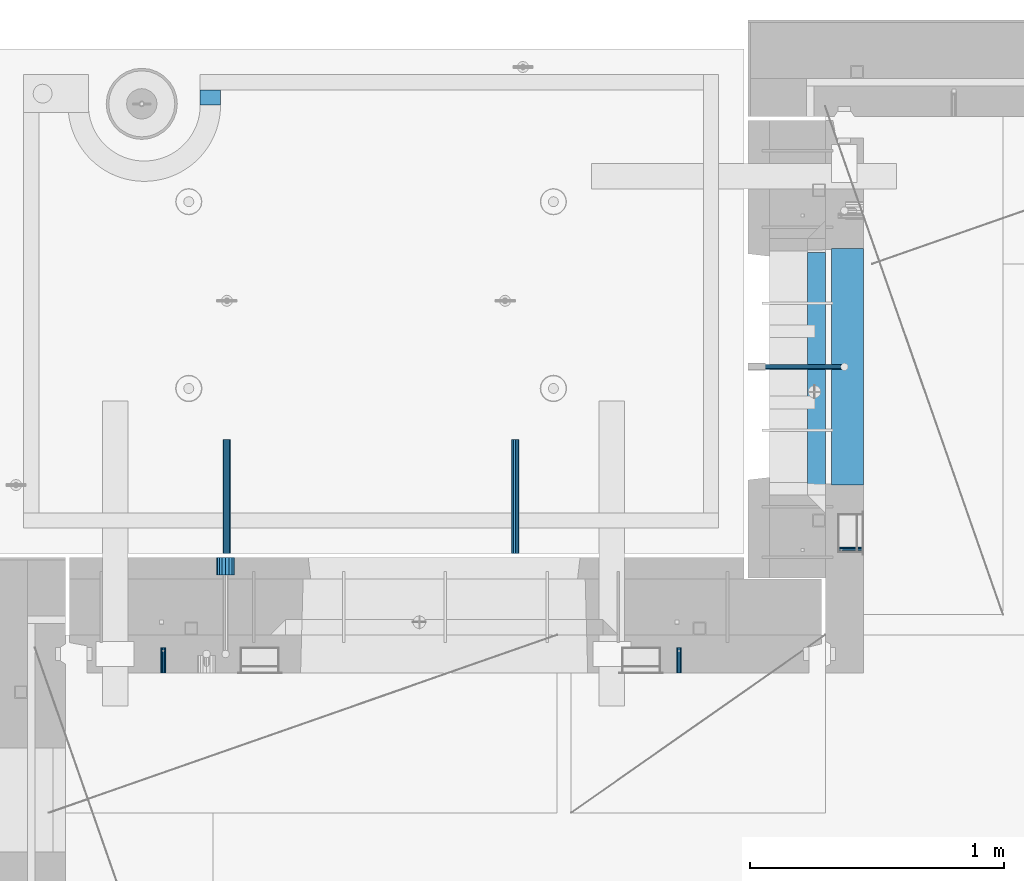
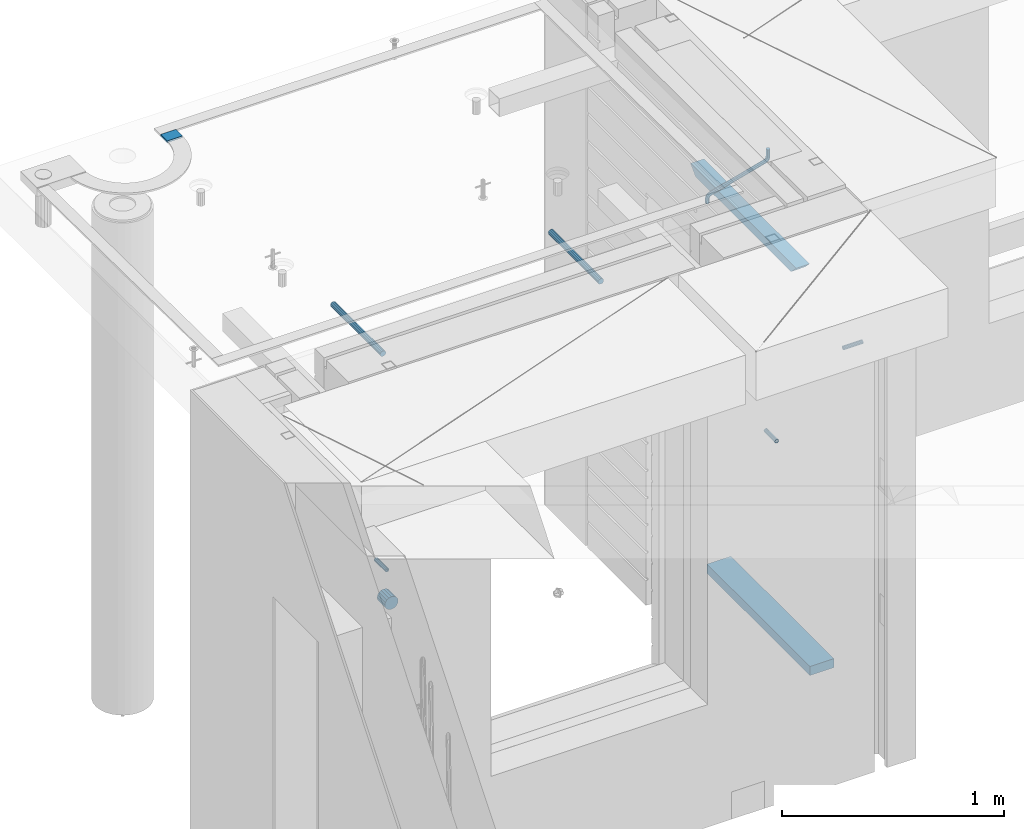
# One storey, part 152 of 341: 10 beams, 8 elements without a shape of their own.
"""IFC2X3 building model written with IfcOpenShell, lengths in millimetres."""

import ifcopenshell
import ifcopenshell.guid

model = None  # the IFC model being written
_history = None  # IfcOwnerHistory: only IFC2X3 demands one
_inside = {}  # id of a spatial element -> (the spatial element, [elements in it])
_under = {}  # id of a project, library or spatial element -> (it, [spatial elements below it])
_declared = {}  # id of a project -> (the project, [libraries it declares])
_typed = {}  # id of a type object -> (the type object, [elements of that type])
_made_of = {}  # id of a material, layer set ... -> (it, [elements and type objects made of it])


def new_model(schema):
    """Start an empty IFC model of exactly this schema.

    Asked for "IFC4X3", IfcOpenShell would pick the latest addendum, in which some entities
    have other attributes; the version numbers below select the first issue.
    IFC2X3 requires an IfcOwnerHistory on every rooted entity: one is made here for all.
    """
    global model, _history
    if schema == "IFC4X3":
        model = ifcopenshell.file(schema_version=(4, 3, 0, 0))
    else:
        model = ifcopenshell.file(schema=schema)
    _inside.clear()
    _under.clear()
    _declared.clear()
    _typed.clear()
    _made_of.clear()
    _history = None
    if model.schema == "IFC2X3":
        org = make("IfcOrganization", Name="unknown")
        user = make(
            "IfcPersonAndOrganization",
            ThePerson=make("IfcPerson", FamilyName="unknown"),
            TheOrganization=org,
        )
        app = make(
            "IfcApplication",
            ApplicationDeveloper=org,
            Version="unknown",
            ApplicationFullName="unknown",
            ApplicationIdentifier="unknown",
        )
        _history = make(
            "IfcOwnerHistory",
            OwningUser=user,
            OwningApplication=app,
            ChangeAction="ADDED",
            CreationDate=0,
        )
    return model


def make(cls, **values):
    """One entity of the class cls with the attributes given. An attribute that is None is left unset."""
    return model.create_entity(
        cls, **{name: value for name, value in values.items() if value is not None}
    )


def rooted(cls, **values):
    """An entity with a GlobalId (a new one), such as an element, a storey or a relation."""
    return make(cls, GlobalId=ifcopenshell.guid.new(), OwnerHistory=_history, **values)


def si_unit(unit_type, name, prefix=None):
    """IfcSIUnit, for example si_unit("LENGTHUNIT", "METRE", prefix="MILLI")."""
    return make("IfcSIUnit", UnitType=unit_type, Prefix=prefix, Name=name)


def assignment(units):
    """IfcUnitAssignment: the units of a project."""
    return None if units is None else make("IfcUnitAssignment", Units=units)


def point(xyz):
    """IfcCartesianPoint."""
    return None if xyz is None else make("IfcCartesianPoint", Coordinates=xyz)


def direction(xyz):
    """IfcDirection."""
    return None if xyz is None else make("IfcDirection", DirectionRatios=xyz)


def frame(location, z_axis=None, x_axis=None):
    """IfcAxis2Placement3D, a coordinate frame: its origin and axes. An axis left out is left unset."""
    return make(
        "IfcAxis2Placement3D",
        Location=point(location),
        Axis=direction(z_axis),
        RefDirection=direction(x_axis),
    )


def origin_with_axes():
    """The frame at (0, 0, 0) with the z axis (0, 0, 1) and the x axis (1, 0, 0) written out."""
    return frame((0.0, 0.0, 0.0), z_axis=(0.0, 0.0, 1.0), x_axis=(1.0, 0.0, 0.0))


def place(relative_to, where):
    """IfcLocalPlacement: puts the frame where relative to a parent placement (None: the world)."""
    return make(
        "IfcLocalPlacement", PlacementRelTo=relative_to, RelativePlacement=where
    )


def context(
    kind, dimensions, precision=None, world=None, true_north=None, identifier=None
):
    """IfcGeometricRepresentationContext, for example the 3D "Model" context."""
    return make(
        "IfcGeometricRepresentationContext",
        ContextIdentifier=identifier,
        ContextType=kind,
        CoordinateSpaceDimension=dimensions,
        Precision=precision,
        WorldCoordinateSystem=world,
        TrueNorth=true_north,
    )


def subcontext(parent, identifier, kind, view, scale=None):
    """IfcGeometricRepresentationSubContext, for example "Body" below "Model"."""
    return make(
        "IfcGeometricRepresentationSubContext",
        ContextIdentifier=identifier,
        ContextType=kind,
        ParentContext=parent,
        TargetScale=scale,
        TargetView=view,
    )


def project(units=None, contexts=None):
    """IfcProject with its units and contexts."""
    return rooted(
        "IfcProject",
        Name="project",
        RepresentationContexts=contexts,
        UnitsInContext=assignment(units),
    )


def spatial(cls, under=None, at=None, **own):
    """A site, building, storey or space (cls), placed at a placement, below another one or the project."""
    s = rooted(cls, ObjectPlacement=at, **own)
    if under is not None:
        _under.setdefault(under.id(), (under, []))[1].append(s)
    return s


def faces_of(points, faces, orient=None, outer=None):
    """IfcFace entities. A face is a list of loops; a loop is a list of indices into points, from 0.

    orient and outer hold one flag for each loop. By default every Orientation is true, the
    first loop of a face is its IfcFaceOuterBound and the others are IfcFaceBound.
    """
    made = []
    for i, loops in enumerate(faces):
        bounds = []
        for j, loop in enumerate(loops):
            is_outer = j == 0 if outer is None else outer[i][j]
            bounds.append(
                make(
                    "IfcFaceOuterBound" if is_outer else "IfcFaceBound",
                    Bound=make("IfcPolyLoop", Polygon=[points[k] for k in loop]),
                    Orientation=True if orient is None else orient[i][j],
                )
            )
        made.append(make("IfcFace", Bounds=bounds))
    return made


def faceted_brep(points, faces, orient=None, outer=None, voids=None):
    """IfcFacetedBrep: a solid bounded by flat faces; with voids (closed shells), ...WithVoids."""
    shared = [point(p) for p in points]
    hull = make("IfcClosedShell", CfsFaces=faces_of(shared, faces, orient, outer))
    if voids is None:
        return make("IfcFacetedBrep", Outer=hull)
    return make(
        "IfcFacetedBrepWithVoids",
        Outer=hull,
        Voids=[
            make(cls, CfsFaces=faces_of(shared, fs, o, b)) for cls, fs, o, b in voids
        ],
    )


def shape(context_of_items, identifier, shape_type, items):
    """IfcShapeRepresentation: the items that make up one representation, for example the "Body"."""
    return make(
        "IfcShapeRepresentation",
        ContextOfItems=context_of_items,
        RepresentationIdentifier=identifier,
        RepresentationType=shape_type,
        Items=items,
    )


def material(Name=None, Category=None):
    """IfcMaterial."""
    return make("IfcMaterial", Name=Name, Category=Category)


def made_of(thing, what):
    """Note that an element or type object is made of a material, layer set ...; save() writes the relation."""
    if what is not None:
        _made_of.setdefault(what.id(), (what, []))[1].append(thing)
    return thing


def type_object(cls, material=None, **own):
    """A type object (cls), such as IfcWallType, which elements share."""
    return made_of(rooted(cls, **own), material)


def element(
    cls,
    number,
    at=None,
    inside=None,
    cuts=None,
    type_object=None,
    material=None,
    context=None,
    identifier="Body",
    shape_type=None,
    held_by="IfcProductDefinitionShape",
    body=None,
    shapes=None,
    **own,
):
    """One element of the class cls, such as IfcWall. Its Tag is "e" and its number.

    at: its placement. inside: the storey or other place that contains it. cuts: it is an
    opening in that element (IfcRelVoidsElement). A single representation is given by context,
    identifier, shape_type and body (its items); several are given by shapes. held_by: the class
    of the entity that holds the representations. save() writes the other relations.
    """
    e = rooted(cls, Tag="e%d" % number, ObjectPlacement=at, **own)
    if body is not None:
        shapes = [shape(context, identifier, shape_type, body)]
    if shapes is not None:
        e.Representation = make(held_by, Representations=shapes)
    if inside is not None:
        _inside.setdefault(inside.id(), (inside, []))[1].append(e)
    if cuts is not None:
        rooted(
            "IfcRelVoidsElement", RelatingBuildingElement=cuts, RelatedOpeningElement=e
        )
    if type_object is not None:
        _typed.setdefault(type_object.id(), (type_object, []))[1].append(e)
    return made_of(e, material)


def aggregate(whole, parts):
    """IfcRelAggregates: a whole, such as a stair, and the parts it consists of."""
    return rooted("IfcRelAggregates", RelatingObject=whole, RelatedObjects=parts)


def save(model, path):
    """Write the relations noted so far, then the file.

    IfcRelAggregates (storeys below a building ...), IfcRelContainedInSpatialStructure (elements
    in a storey), IfcRelDefinesByType, IfcRelAssociatesMaterial and IfcRelDeclares: one each for
    every whole, place, type object, material and project.
    """
    for whole, parts in _under.values():
        aggregate(whole, parts)
    for where, things in _inside.values():
        rooted(
            "IfcRelContainedInSpatialStructure",
            RelatedElements=things,
            RelatingStructure=where,
        )
    for kind, things in _typed.values():
        rooted("IfcRelDefinesByType", RelatedObjects=things, RelatingType=kind)
    for what, things in _made_of.values():
        rooted("IfcRelAssociatesMaterial", RelatedObjects=things, RelatingMaterial=what)
    for by, libraries in _declared.values():
        rooted("IfcRelDeclares", RelatingContext=by, RelatedDefinitions=libraries)
    model.write(path)


model = new_model("IFC2X3")

# Units and contexts
model_context = context("Model", 3, precision=1e-05, world=origin_with_axes())
body_context = subcontext(model_context, "Body", "Model", "MODEL_VIEW")
ifc_project = project(units=[si_unit("LENGTHUNIT", "METRE", prefix="MILLI"), si_unit("AREAUNIT", "SQUARE_METRE"), si_unit("VOLUMEUNIT", "CUBIC_METRE"), si_unit("MASSUNIT", "GRAM", prefix="KILO"), si_unit("TIMEUNIT", "SECOND"), si_unit("PLANEANGLEUNIT", "RADIAN"), si_unit("SOLIDANGLEUNIT", "STERADIAN"), si_unit("THERMODYNAMICTEMPERATUREUNIT", "DEGREE_CELSIUS"), si_unit("LUMINOUSINTENSITYUNIT", "LUMEN")], contexts=[model_context])

# Site, building, storey
site_placement = place(None, origin_with_axes())
site = spatial("IfcSite", under=ifc_project, at=site_placement, CompositionType="ELEMENT")
building_placement = place(site_placement, origin_with_axes())
building = spatial("IfcBuilding", under=site, at=building_placement, CompositionType="ELEMENT")
storey_placement = place(building_placement, origin_with_axes())
storey = spatial("IfcBuildingStorey", under=building, at=storey_placement, Name="5", CompositionType="ELEMENT", Elevation=0.0)

# Assembly, beam
assembly_1_placement = place(storey_placement, origin_with_axes())
assembly_1 = element("IfcElementAssembly", 1, at=assembly_1_placement, inside=storey, AssemblyPlace="NOTDEFINED", PredefinedType="REINFORCEMENT_UNIT")
ifc_material_1 = material(Name="CONCRETE/C25/30")
beam_type_1 = type_object("IfcBeamType", PredefinedType="NOTDEFINED")
beam_1_placement = place(assembly_1_placement, frame((10955.0, 22139.9998901814, 96080.0), z_axis=(0.0, 0.0, -1.0), x_axis=(0.0, -1.0, 0.0)))
beam_1 = element("IfcBeam", 2, at=beam_1_placement, type_object=beam_type_1, material=ifc_material_1, Name="SK", context=body_context, shape_type="Brep", body=[
    faceted_brep([(100.641025641038, 35.0, 20.6410256410309), (55.0, 35.0, -25.0), (55.0, -35.0, -25.0), (98.8461538461561, -35.0, 18.8461538461561), (966.153464684117, -35.0, 18.8461538461561), (964.358592889246, 35.0, 20.6410256410309), (1009.99961853027, 35.0, -25.0), (1009.99961853027, -35.0, -25.0)], [[[0, 1, 2, 3]], [[0, 3, 4, 5]], [[1, 0, 5, 6]], [[2, 1, 6, 7]], [[3, 2, 7, 4]], [[4, 7, 6, 5]]]),
])

# Assemblies, beams
assembly_2_placement = place(storey_placement, origin_with_axes())
assembly_2 = element("IfcElementAssembly", 3, at=assembly_2_placement, inside=storey, AssemblyPlace="NOTDEFINED", PredefinedType="REINFORCEMENT_UNIT")
assembly_3_placement = place(assembly_2_placement, origin_with_axes())
assembly_3 = element("IfcElementAssembly", 4, at=assembly_3_placement, Name="Steel Assembly", AssemblyPlace="NOTDEFINED", PredefinedType="RIGID_FRAME")
ifc_material_2 = material(Name="STEEL/Steel_Undefined")
beam_type_2 = type_object("IfcBeamType", PredefinedType="NOTDEFINED")
beam_2_placement = place(assembly_3_placement, frame((8384.50481277243, 20430.0, 95754.84), z_axis=(-1.0, 3.00000001838171e-08, 0.0), x_axis=(0.0, 1.0, 0.0)))
beam_2 = element("IfcBeam", 5, at=beam_2_placement, type_object=beam_type_2, material=ifc_material_2, context=body_context, shape_type="Brep", body=[
    faceted_brep([(0.0, -8.49999999999272, -1.45519152283669e-11), (0.0, -7.36121593215648, 4.24999999998545), (100.000000000262, -7.36121593215648, 4.24999999998545), (100.000000000262, -8.49999999999272, -1.45519152283669e-11), (0.0, -4.24999999998545, 7.36121593216376), (100.000000000262, -4.24999999998545, 7.36121593216376), (0.0, 1.45519152283669e-11, 8.49999999998545), (100.000000000262, 1.45519152283669e-11, 8.49999999998545), (0.0, 4.25000000001455, 7.36121593216376), (100.000000000262, 4.25000000001455, 7.36121593216376), (0.0, 7.36121593217104, 4.24999999998545), (100.000000000262, 7.36121593217104, 4.24999999998545), (0.0, 8.50000000000728, 0.0), (100.000000000262, 8.50000000000728, 0.0), (0.0, 7.36121593217104, -4.25000000001455), (100.000000000262, 7.36121593217104, -4.25000000001455), (0.0, 4.25000000000728, -7.36121593219286), (100.000000000262, 4.25000000000728, -7.36121593219286), (0.0, 7.27595761418343e-12, -8.5), (100.000000000262, 7.27595761418343e-12, -8.5), (0.0, -4.24999999999272, -7.36121593217831), (100.000000000262, -4.24999999999272, -7.36121593217831), (0.0, -7.36121593215648, -4.25), (100.000000000262, -7.36121593215648, -4.25), (0.0, -10.4999999999927, -1.45519152283669e-11), (0.0, -9.09326673972828, -5.25000000001455), (100.000000000262, -9.09326673972828, -5.25000000001455), (100.000000000262, -10.4999999999927, -1.45519152283669e-11), (0.0, -5.24999999998545, -9.09326673974283), (100.000000000262, -5.24999999998545, -9.09326673974283), (0.0, 7.27595761418343e-12, -10.5), (100.000000000262, 7.27595761418343e-12, -10.5), (0.0, 5.25000000001455, -9.09326673975738), (100.000000000262, 5.25000000001455, -9.09326673975738), (0.0, 9.09326673975011, -5.25000000001455), (100.000000000262, 9.09326673975011, -5.25000000001455), (0.0, 10.5000000000073, -1.45519152283669e-11), (100.000000000262, 10.5000000000073, -1.45519152283669e-11), (0.0, 9.09326673975011, 5.25), (100.000000000262, 9.09326673975011, 5.25), (0.0, 5.25000000000728, 9.09326673972828), (100.000000000262, 5.25000000000728, 9.09326673972828), (0.0, 1.45519152283669e-11, 10.4999999999854), (100.000000000262, 1.45519152283669e-11, 10.4999999999854), (0.0, -5.24999999999272, 9.09326673972828), (100.000000000262, -5.24999999999272, 9.09326673972828), (0.0, -9.09326673972828, 5.24999999998545), (100.000000000262, -9.09326673972828, 5.24999999998545)], [[[0, 1, 2, 3]], [[1, 4, 5, 2]], [[4, 6, 7, 5]], [[6, 8, 9, 7]], [[8, 10, 11, 9]], [[10, 12, 13, 11]], [[12, 14, 15, 13]], [[14, 16, 17, 15]], [[16, 18, 19, 17]], [[18, 20, 21, 19]], [[20, 22, 23, 21]], [[22, 0, 3, 23]], [[24, 25, 26, 27]], [[25, 28, 29, 26]], [[28, 30, 31, 29]], [[30, 32, 33, 31]], [[32, 34, 35, 33]], [[34, 36, 37, 35]], [[36, 38, 39, 37]], [[38, 40, 41, 39]], [[40, 42, 43, 41]], [[42, 44, 45, 43]], [[44, 46, 47, 45]], [[46, 24, 27, 47]], [[29, 31, 33, 35, 37, 39, 41, 43, 45, 47, 27, 26], [5, 7, 9, 11, 13, 15, 17, 19, 21, 23, 3, 2]], [[46, 44, 42, 40, 38, 36, 34, 32, 30, 28, 25, 24], [22, 20, 18, 16, 14, 12, 10, 8, 6, 4, 1, 0]]]),
])
aggregate(assembly_3, [beam_2])
assembly_4_placement = place(assembly_2_placement, origin_with_axes())
assembly_4 = element("IfcElementAssembly", 6, at=assembly_4_placement, Name="Steel Assembly", AssemblyPlace="NOTDEFINED", PredefinedType="RIGID_FRAME")
beam_3_placement = place(assembly_4_placement, frame((10414.5048127724, 20430.0, 95754.84), z_axis=(-1.0, 3.00000001838171e-08, 0.0), x_axis=(0.0, 1.0, 0.0)))
beam_3 = element("IfcBeam", 7, at=beam_3_placement, type_object=beam_type_2, material=ifc_material_2, context=body_context, shape_type="Brep", body=[
    faceted_brep([(0.0, -8.49999999999272, -1.45519152283669e-11), (0.0, -7.36121593215648, 4.24999999998545), (100.000000000262, -7.36121593215648, 4.24999999998545), (100.000000000262, -8.49999999999272, -1.45519152283669e-11), (0.0, -4.24999999998545, 7.36121593216376), (100.000000000262, -4.24999999998545, 7.36121593216376), (0.0, 1.45519152283669e-11, 8.49999999998545), (100.000000000262, 1.45519152283669e-11, 8.49999999998545), (0.0, 4.25000000001455, 7.36121593216376), (100.000000000262, 4.25000000001455, 7.36121593216376), (0.0, 7.36121593217104, 4.24999999998545), (100.000000000262, 7.36121593217104, 4.24999999998545), (0.0, 8.50000000000728, 0.0), (100.000000000262, 8.50000000000728, 0.0), (0.0, 7.36121593217104, -4.25000000001455), (100.000000000262, 7.36121593217104, -4.25000000001455), (0.0, 4.25000000000728, -7.36121593219286), (100.000000000262, 4.25000000000728, -7.36121593219286), (0.0, 7.27595761418343e-12, -8.5), (100.000000000262, 7.27595761418343e-12, -8.5), (0.0, -4.24999999999272, -7.36121593217831), (100.000000000262, -4.24999999999272, -7.36121593217831), (0.0, -7.36121593215648, -4.25), (100.000000000262, -7.36121593215648, -4.25), (0.0, -10.4999999999927, -1.45519152283669e-11), (0.0, -9.09326673972828, -5.25000000001455), (100.000000000262, -9.09326673972828, -5.25000000001455), (100.000000000262, -10.4999999999927, -1.45519152283669e-11), (0.0, -5.24999999998545, -9.09326673974283), (100.000000000262, -5.24999999998545, -9.09326673974283), (0.0, 7.27595761418343e-12, -10.5), (100.000000000262, 7.27595761418343e-12, -10.5), (0.0, 5.25000000001455, -9.09326673975738), (100.000000000262, 5.25000000001455, -9.09326673975738), (0.0, 9.09326673975011, -5.25000000001455), (100.000000000262, 9.09326673975011, -5.25000000001455), (0.0, 10.5000000000073, -1.45519152283669e-11), (100.000000000262, 10.5000000000073, -1.45519152283669e-11), (0.0, 9.09326673975011, 5.25), (100.000000000262, 9.09326673975011, 5.25), (0.0, 5.25000000000728, 9.09326673972828), (100.000000000262, 5.25000000000728, 9.09326673972828), (0.0, 1.45519152283669e-11, 10.4999999999854), (100.000000000262, 1.45519152283669e-11, 10.4999999999854), (0.0, -5.24999999999272, 9.09326673972828), (100.000000000262, -5.24999999999272, 9.09326673972828), (0.0, -9.09326673972828, 5.24999999998545), (100.000000000262, -9.09326673972828, 5.24999999998545)], [[[0, 1, 2, 3]], [[1, 4, 5, 2]], [[4, 6, 7, 5]], [[6, 8, 9, 7]], [[8, 10, 11, 9]], [[10, 12, 13, 11]], [[12, 14, 15, 13]], [[14, 16, 17, 15]], [[16, 18, 19, 17]], [[18, 20, 21, 19]], [[20, 22, 23, 21]], [[22, 0, 3, 23]], [[24, 25, 26, 27]], [[25, 28, 29, 26]], [[28, 30, 31, 29]], [[30, 32, 33, 31]], [[32, 34, 35, 33]], [[34, 36, 37, 35]], [[36, 38, 39, 37]], [[38, 40, 41, 39]], [[40, 42, 43, 41]], [[42, 44, 45, 43]], [[44, 46, 47, 45]], [[46, 24, 27, 47]], [[29, 31, 33, 35, 37, 39, 41, 43, 45, 47, 27, 26], [5, 7, 9, 11, 13, 15, 17, 19, 21, 23, 3, 2]], [[46, 44, 42, 40, 38, 36, 34, 32, 30, 28, 25, 24], [22, 20, 18, 16, 14, 12, 10, 8, 6, 4, 1, 0]]]),
])
aggregate(assembly_4, [beam_3])

# Assembly, beam
assembly_5_placement = place(assembly_1_placement, origin_with_axes())
assembly_5 = element("IfcElementAssembly", 8, at=assembly_5_placement, Name="Steel Assembly", AssemblyPlace="NOTDEFINED", PredefinedType="RIGID_FRAME")
beam_4_placement = place(assembly_5_placement, frame((11140.0, 20914.9954408996, 95755.0), z_axis=(0.0, -1.0, 0.0), x_axis=(-1.0, 3.00000001838171e-08, 0.0)))
beam_4 = element("IfcBeam", 9, at=beam_4_placement, type_object=beam_type_2, material=ifc_material_2, Name="M16", context=body_context, shape_type="Brep", body=[
    faceted_brep([(0.0, -8.49999999999272, -1.45519152283669e-11), (0.0, -7.36121593215648, 4.24999999998545), (100.000000000262, -7.36121593215648, 4.24999999998545), (100.000000000262, -8.49999999999272, -1.45519152283669e-11), (0.0, -4.24999999998545, 7.36121593216376), (100.000000000262, -4.24999999998545, 7.36121593216376), (0.0, 1.45519152283669e-11, 8.49999999998545), (100.000000000262, 1.45519152283669e-11, 8.49999999998545), (0.0, 4.25000000001455, 7.36121593216376), (100.000000000262, 4.25000000001455, 7.36121593216376), (0.0, 7.36121593217104, 4.24999999998545), (100.000000000262, 7.36121593217104, 4.24999999998545), (0.0, 8.50000000000728, 0.0), (100.000000000262, 8.50000000000728, 0.0), (0.0, 7.36121593217104, -4.25000000001455), (100.000000000262, 7.36121593217104, -4.25000000001455), (0.0, 4.25000000000728, -7.36121593219286), (100.000000000262, 4.25000000000728, -7.36121593219286), (0.0, 7.27595761418343e-12, -8.5), (100.000000000262, 7.27595761418343e-12, -8.5), (0.0, -4.24999999999272, -7.36121593217831), (100.000000000262, -4.24999999999272, -7.36121593217831), (0.0, -7.36121593215648, -4.25), (100.000000000262, -7.36121593215648, -4.25), (0.0, -10.4999999999927, -1.45519152283669e-11), (0.0, -9.09326673972828, -5.25000000001455), (100.000000000262, -9.09326673972828, -5.25000000001455), (100.000000000262, -10.4999999999927, -1.45519152283669e-11), (0.0, -5.24999999998545, -9.09326673974283), (100.000000000262, -5.24999999998545, -9.09326673974283), (0.0, 7.27595761418343e-12, -10.5), (100.000000000262, 7.27595761418343e-12, -10.5), (0.0, 5.25000000001455, -9.09326673975738), (100.000000000262, 5.25000000001455, -9.09326673975738), (0.0, 9.09326673975011, -5.25000000001455), (100.000000000262, 9.09326673975011, -5.25000000001455), (0.0, 10.5000000000073, -1.45519152283669e-11), (100.000000000262, 10.5000000000073, -1.45519152283669e-11), (0.0, 9.09326673975011, 5.25), (100.000000000262, 9.09326673975011, 5.25), (0.0, 5.25000000000728, 9.09326673972828), (100.000000000262, 5.25000000000728, 9.09326673972828), (0.0, 1.45519152283669e-11, 10.4999999999854), (100.000000000262, 1.45519152283669e-11, 10.4999999999854), (0.0, -5.24999999999272, 9.09326673972828), (100.000000000262, -5.24999999999272, 9.09326673972828), (0.0, -9.09326673972828, 5.24999999998545), (100.000000000262, -9.09326673972828, 5.24999999998545)], [[[0, 1, 2, 3]], [[1, 4, 5, 2]], [[4, 6, 7, 5]], [[6, 8, 9, 7]], [[8, 10, 11, 9]], [[10, 12, 13, 11]], [[12, 14, 15, 13]], [[14, 16, 17, 15]], [[16, 18, 19, 17]], [[18, 20, 21, 19]], [[20, 22, 23, 21]], [[22, 0, 3, 23]], [[24, 25, 26, 27]], [[25, 28, 29, 26]], [[28, 30, 31, 29]], [[30, 32, 33, 31]], [[32, 34, 35, 33]], [[34, 36, 37, 35]], [[36, 38, 39, 37]], [[38, 40, 41, 39]], [[40, 42, 43, 41]], [[42, 44, 45, 43]], [[44, 46, 47, 45]], [[46, 24, 27, 47]], [[29, 31, 33, 35, 37, 39, 41, 43, 45, 47, 27, 26], [5, 7, 9, 11, 13, 15, 17, 19, 21, 23, 3, 2]], [[46, 44, 42, 40, 38, 36, 34, 32, 30, 28, 25, 24], [22, 20, 18, 16, 14, 12, 10, 8, 6, 4, 1, 0]]]),
])
aggregate(assembly_5, [beam_4])

# Beam
ifc_material_3 = material()
beam_type_3 = type_object("IfcBeamType", Name="D20", PredefinedType="NOTDEFINED")
beam_5_placement = place(assembly_1_placement, frame((10747.93, 21634.9982799665, 96220.28), z_axis=(0.999209485784166, 0.00020572799995638, -0.0397537569914116), x_axis=(0.0397537569984931, -6.39999925638531e-08, 0.999209506962629)))
beam_5 = element("IfcBeam", 10, at=beam_5_placement, type_object=beam_type_3, material=ifc_material_3, Name="JM20", ObjectType="D20", context=body_context, shape_type="Brep", body=[
    faceted_brep([(0.0, -10.0, 0.0), (-4.19531716033816e-08, -7.07106781186667, -7.07106781187031), (26.3851730625611, -7.07106780271351, -7.07106779974674), (26.3851730660535, -9.99999999077045, 1.18243406177498e-08), (0.0, 0.0, -10.0), (26.3851730589668, 9.14587872102857e-09, -9.99999998788189), (4.196772351861e-08, 7.07106781186303, -7.07106781186667), (26.3851730576571, 7.07106782101255, -7.0710677997472), (0.0, 10.0, 0.0), (26.3851730593888, 10.0000000091495, 1.21176526590716e-08), (4.196772351861e-08, 7.07106781185939, 7.07106781185939), (26.3851730631723, 7.07106782101619, 7.07106782398387), (0.0, 0.0, 10.0), (26.3851730667375, 9.15315467864275e-09, 10.0000000121181), (-4.19531716033816e-08, -7.07106781187031, 7.07106781185939), (26.3851730680617, -7.07106780271351, 7.07106782398296), (38.6387990555377, 0.00053833780111745, -7.38336449283906), (37.4430586178205, -7.07058200552274, -4.70977034770021), (34.5550974405633, -9.99964106806146, 1.74460312923975), (31.6666440137633, -7.07083577596131, 8.19887149183023), (30.4697151806322, 0.000179452214069897, 10.8722118684241), (31.6654556183639, 7.07129979554884, 8.19861772327886), (34.5534167956066, 10.0003588580803, 1.74424424634026), (37.4418702223775, 7.07155356597286, -4.71002411625204), (46.5698109210789, 7.07292605872499, 1.96124086770624), (48.7548734831362, 0.00205940803425619, 0.0100898832683924), (41.2967727296491, 10.0013728005906, 6.67270684289633), (36.0246331664675, 7.07195524891722, 11.3845749391899), (33.8417400848848, 0.000686475628754124, 13.3366967298962), (36.0268026468402, -7.07018017507653, 11.385545745416), (41.2998408382991, -9.99862691692761, 6.67407977023777), (46.5719804015243, -7.06920936526149, 1.96221167398289), (52.1766955363273, 7.07494587836845, 11.77897587077), (54.9687243336812, 0.00429788071051007, 10.8906314292522), (45.4389138642146, 10.0028649622, 13.9256551011317), (38.7022804405424, 7.07291984242329, 16.0731735411446), (35.9130237601494, 0.00143263318750542, 16.9635440140905), (38.7050525575032, -7.06921536447044, 16.0751995724927), (45.4428342298197, -9.99713444846202, 13.9285203429881), (52.1794676532882, -7.06718932852891, 11.7810019021831), (142.166420299589, -7.00909836739083, 294.143799597011), (135.429786872017, -9.93904348683645, 296.291318034092), (144.955676979953, 0.0623888418631395, 293.253429124143), (142.163648182657, 7.13303683951744, 294.141773565681), (135.425866510661, 10.0609559233271, 296.288452795829), (128.689233087061, 7.13101080351771, 298.435971235634), (125.899976406712, 0.0595235942673753, 299.326341708503), (128.692005203993, -7.01112440339057, 298.437997266966), (147.068569920637, 0.0631443010061048, 296.926548661886), (144.897857494318, -7.00812174957537, 298.892215917644), (139.655137467547, -9.93753272500544, 303.636800386314), (134.411524128242, -7.00907940566321, 308.380988833921), (132.238655054738, 0.0617899707685865, 310.345700010335), (134.409367481101, 7.13305602133914, 308.38003275464), (139.652087507944, 10.0624669967765, 303.63544828606), (144.895700847192, 7.13401367743427, 298.891259838389), (149.349355837621, 7.13466950711154, 302.082919188319), (150.512901837996, 0.0636515012993186, 299.394888529177), (146.541460642286, 10.0634815017911, 308.572636332), (143.734043175544, 7.13442914049301, 315.062451673432), (142.571650514263, 0.0633115715718304, 317.750719402909), (143.735196514695, -7.0077064342513, 315.062688743805), (146.543091710148, -9.93651842893087, 308.572971600169), (149.350509176773, -7.0074660676255, 302.083156258706), (154.724909358454, 7.13488656737172, 303.143653317829), (154.670204234542, 0.063819369621342, 300.215230568659), (154.856921558763, 10.0638172729959, 310.213489346082), (154.988909878753, 7.13488360238989, 317.283324591871), (155.043557350815, 0.0638151764978829, 320.211745451903), (154.988852227005, -7.00725202125614, 317.28332270274), (154.856840031658, -9.93618272723688, 310.213486674455), (154.724851706691, -7.00724905626703, 303.143651428684), (199.544700311235, -7.00743165723543, 302.30682413155), (199.676688632229, -9.93636532781238, 309.37665937721), (199.490052838737, 0.0636367686238373, 299.378403271518), (199.544757962984, 7.13470396637786, 302.306826020583), (199.676770164122, 10.0636346720203, 309.376662048705), (199.808758485131, 7.13470100144696, 316.446497294365), (199.863405957614, 0.0636325755804137, 319.374918154397), (199.808700833368, -7.00743462216269, 316.446495405334)], [[[0, 1, 2, 3]], [[1, 4, 5, 2]], [[4, 6, 7, 5]], [[6, 8, 9, 7]], [[8, 10, 11, 9]], [[10, 12, 13, 11]], [[12, 14, 15, 13]], [[14, 0, 3, 15]], [[14, 12, 10, 8, 6, 4, 1, 0]], [[2, 5, 16, 17]], [[3, 2, 17, 18]], [[15, 3, 18, 19]], [[13, 15, 19, 20]], [[11, 13, 20, 21]], [[9, 11, 21, 22]], [[7, 9, 22, 23]], [[5, 7, 23, 16]], [[23, 24, 25, 16]], [[22, 26, 24, 23]], [[21, 27, 26, 22]], [[20, 28, 27, 21]], [[19, 29, 28, 20]], [[18, 30, 29, 19]], [[17, 31, 30, 18]], [[16, 25, 31, 17]], [[24, 32, 33, 25]], [[26, 34, 32, 24]], [[27, 35, 34, 26]], [[28, 36, 35, 27]], [[29, 37, 36, 28]], [[30, 38, 37, 29]], [[31, 39, 38, 30]], [[25, 33, 39, 31]], [[38, 39, 40, 41]], [[39, 33, 42, 40]], [[33, 32, 43, 42]], [[32, 34, 44, 43]], [[34, 35, 45, 44]], [[35, 36, 46, 45]], [[36, 37, 47, 46]], [[37, 38, 41, 47]], [[40, 42, 48, 49]], [[41, 40, 49, 50]], [[47, 41, 50, 51]], [[46, 47, 51, 52]], [[45, 46, 52, 53]], [[44, 45, 53, 54]], [[43, 44, 54, 55]], [[42, 43, 55, 48]], [[55, 56, 57, 48]], [[54, 58, 56, 55]], [[53, 59, 58, 54]], [[52, 60, 59, 53]], [[51, 61, 60, 52]], [[50, 62, 61, 51]], [[49, 63, 62, 50]], [[48, 57, 63, 49]], [[56, 64, 65, 57]], [[58, 66, 64, 56]], [[59, 67, 66, 58]], [[60, 68, 67, 59]], [[61, 69, 68, 60]], [[62, 70, 69, 61]], [[63, 71, 70, 62]], [[57, 65, 71, 63]], [[70, 71, 72, 73]], [[71, 65, 74, 72]], [[65, 64, 75, 74]], [[64, 66, 76, 75]], [[66, 67, 77, 76]], [[67, 68, 78, 77]], [[68, 69, 79, 78]], [[69, 70, 73, 79]], [[74, 75, 76, 77, 78, 79, 73, 72]]]),
])

beam_type_4 = type_object("IfcBeamType", Name="D70", PredefinedType="NOTDEFINED")
beam_6_placement = place(assembly_2_placement, frame((8630.0, 20884.9951872276, 95255.0), z_axis=(0.0, 0.0, 1.0), x_axis=(0.0, -1.0, 0.0)))
beam_6 = element("IfcBeam", 11, at=beam_6_placement, type_object=beam_type_4, material=ifc_material_3, ObjectType="D70", context=body_context, shape_type="Brep", body=[
    faceted_brep([(0.0, -35.0, 0.0), (0.0, -32.3357836378964, -13.3939201327739), (70.0, -32.3357836378964, -13.3939201327739), (70.0, -35.0, 0.0), (0.0, -24.7487373415279, -24.7487373415352), (70.0, -24.7487373415279, -24.7487373415352), (0.0, -13.3939201327776, -32.3357836379), (70.0, -13.3939201327776, -32.3357836379), (0.0, 0.0, -35.0), (70.0, 0.0, -35.0), (0.0, 13.3939201327776, -32.3357836379), (70.0, 13.3939201327776, -32.3357836379), (0.0, 24.7487373415279, -24.7487373415352), (70.0, 24.7487373415279, -24.7487373415352), (0.0, 32.3357836378964, -13.3939201327739), (70.0, 32.3357836378964, -13.3939201327739), (0.0, 35.0, 0.0), (70.0, 35.0, 0.0), (0.0, 32.3357836378964, 13.3939201327739), (70.0, 32.3357836378964, 13.3939201327739), (0.0, 24.7487373415279, 24.7487373415352), (70.0, 24.7487373415279, 24.7487373415352), (0.0, 13.3939201327776, 32.3357836379), (70.0, 13.3939201327776, 32.3357836379), (0.0, 0.0, 35.0), (70.0, 0.0, 35.0), (0.0, -13.3939201327776, 32.3357836379), (70.0, -13.3939201327776, 32.3357836379), (0.0, -24.7487373415279, 24.7487373415352), (70.0, -24.7487373415279, 24.7487373415352), (0.0, -32.3357836378964, 13.3939201327739), (70.0, -32.3357836378964, 13.3939201327739)], [[[0, 1, 2, 3]], [[1, 4, 5, 2]], [[4, 6, 7, 5]], [[6, 8, 9, 7]], [[8, 10, 11, 9]], [[10, 12, 13, 11]], [[12, 14, 15, 13]], [[14, 16, 17, 15]], [[16, 18, 19, 17]], [[18, 20, 21, 19]], [[20, 22, 23, 21]], [[22, 24, 25, 23]], [[24, 26, 27, 25]], [[26, 28, 29, 27]], [[28, 30, 31, 29]], [[30, 0, 3, 31]], [[5, 7, 9, 11, 13, 15, 17, 19, 21, 23, 25, 27, 29, 31, 3, 2]], [[30, 28, 26, 24, 22, 20, 18, 16, 14, 12, 10, 8, 6, 4, 1, 0]]]),
])

aggregate(assembly_2, [beam_6, assembly_3, assembly_4])

ifc_material_4 = material(Name="TIMBER/PUU")
beam_type_5 = type_object("IfcBeamType", PredefinedType="NOTDEFINED")
beam_7_placement = place(assembly_1_placement, frame((11077.5, 21169.9999618525, 93830.0), z_axis=(0.0, 0.0, 1.0), x_axis=(0.0, 1.0, 0.0)))
beam_7 = element("IfcBeam", 12, at=beam_7_placement, type_object=beam_type_5, material=ifc_material_4, context=body_context, shape_type="Brep", body=[
    faceted_brep([(0.0, 62.5, -25.0), (0.0, 62.5, 25.0), (930.0, 62.5, 25.0), (930.0, 62.5, -25.0), (0.0, -62.5, 25.0), (930.0, -62.5, 25.0), (0.0, -62.5, -25.0), (930.0, -62.5, -25.0)], [[[0, 1, 2, 3]], [[1, 4, 5, 2]], [[4, 6, 7, 5]], [[6, 0, 3, 7]], [[5, 7, 3, 2]], [[6, 4, 1, 0]]]),
])

aggregate(assembly_1, [beam_5, assembly_5, beam_7, beam_1])

# Assemblies, beams
assembly_6_placement = place(storey_placement, origin_with_axes())
assembly_6 = element("IfcElementAssembly", 13, at=assembly_6_placement, inside=storey, AssemblyPlace="NOTDEFINED", PredefinedType="REINFORCEMENT_UNIT")
assembly_7_placement = place(assembly_6_placement, origin_with_axes())
assembly_7 = element("IfcElementAssembly", 14, at=assembly_7_placement, Name="Steel Assembly", AssemblyPlace="NOTDEFINED", PredefinedType="RIGID_FRAME")
ifc_material_5 = material(Name="STEEL/S235JR")
beam_type_6 = type_object("IfcBeamType", Name="D30", PredefinedType="NOTDEFINED")
beam_8_placement = place(assembly_7_placement, frame((8634.99985675633, 20900.0253394533, 96575.0), z_axis=(0.0, 0.0, 1.0), x_axis=(0.0, 1.0, 0.0)))
beam_8 = element("IfcBeam", 15, at=beam_8_placement, type_object=beam_type_6, material=ifc_material_5, Name="Rd30", ObjectType="D30", context=body_context, shape_type="Brep", body=[
    faceted_brep([(0.0, -15.0, 0.0), (0.0, -12.9903810567666, -7.5), (450.0, -12.9903810567666, -7.5), (450.0, -15.0, 0.0), (0.0, -7.5, -12.9903810567666), (450.0, -7.5, -12.990381056763), (0.0, 0.0, -15.0), (450.0, 0.0, -15.0), (0.0, 7.5, -12.9903810567666), (450.0, 7.5, -12.990381056763), (0.0, 12.9903810567666, -7.5), (450.0, 12.9903810567666, -7.5), (0.0, 15.0, 0.0), (450.0, 15.0, 0.0), (0.0, 12.9903810567666, 7.5), (450.0, 12.9903810567666, 7.5), (0.0, 7.5, 12.9903810567666), (450.0, 7.5, 12.990381056763), (0.0, 0.0, 15.0), (450.0, 0.0, 15.0), (0.0, -7.5, 12.9903810567666), (450.0, -7.5, 12.990381056763), (0.0, -12.9903810567666, 7.5), (450.0, -12.9903810567666, 7.5)], [[[0, 1, 2, 3]], [[1, 4, 5, 2]], [[4, 6, 7, 5]], [[6, 8, 9, 7]], [[8, 10, 11, 9]], [[10, 12, 13, 11]], [[12, 14, 15, 13]], [[14, 16, 17, 15]], [[16, 18, 19, 17]], [[18, 20, 21, 19]], [[20, 22, 23, 21]], [[22, 0, 3, 23]], [[5, 7, 9, 11, 13, 15, 17, 19, 21, 23, 3, 2]], [[22, 20, 18, 16, 14, 12, 10, 8, 6, 4, 1, 0]]]),
])
aggregate(assembly_7, [beam_8])
assembly_8_placement = place(assembly_6_placement, origin_with_axes())
assembly_8 = element("IfcElementAssembly", 16, at=assembly_8_placement, Name="Steel Assembly", AssemblyPlace="NOTDEFINED", PredefinedType="RIGID_FRAME")
beam_9_placement = place(assembly_8_placement, frame((9769.99985700661, 20900.0152136098, 96575.0), z_axis=(0.0, 0.0, 1.0), x_axis=(0.0, 1.0, 0.0)))
beam_9 = element("IfcBeam", 17, at=beam_9_placement, type_object=beam_type_6, material=ifc_material_5, Name="Rd30", ObjectType="D30", context=body_context, shape_type="Brep", body=[
    faceted_brep([(0.0, -15.0, 0.0), (0.0, -12.9903810567666, -7.5), (450.0, -12.9903810567666, -7.5), (450.0, -15.0, 0.0), (0.0, -7.5, -12.9903810567666), (450.0, -7.5, -12.990381056763), (0.0, 0.0, -15.0), (450.0, 0.0, -15.0), (0.0, 7.5, -12.9903810567666), (450.0, 7.5, -12.990381056763), (0.0, 12.9903810567666, -7.5), (450.0, 12.9903810567666, -7.5), (0.0, 15.0, 0.0), (450.0, 15.0, 0.0), (0.0, 12.9903810567666, 7.5), (450.0, 12.9903810567666, 7.5), (0.0, 7.5, 12.9903810567666), (450.0, 7.5, 12.990381056763), (0.0, 0.0, 15.0), (450.0, 0.0, 15.0), (0.0, -7.5, 12.9903810567666), (450.0, -7.5, 12.990381056763), (0.0, -12.9903810567666, 7.5), (450.0, -12.9903810567666, 7.5)], [[[0, 1, 2, 3]], [[1, 4, 5, 2]], [[4, 6, 7, 5]], [[6, 8, 9, 7]], [[8, 10, 11, 9]], [[10, 12, 13, 11]], [[12, 14, 15, 13]], [[14, 16, 17, 15]], [[16, 18, 19, 17]], [[18, 20, 21, 19]], [[20, 22, 23, 21]], [[22, 0, 3, 23]], [[5, 7, 9, 11, 13, 15, 17, 19, 21, 23, 3, 2]], [[22, 20, 18, 16, 14, 12, 10, 8, 6, 4, 1, 0]]]),
])
aggregate(assembly_8, [beam_9])
ifc_material_6 = material(Name="CONCRETE/Concrete_Undefined")
beam_type_7 = type_object("IfcBeamType", PredefinedType="NOTDEFINED")
beam_10_placement = place(assembly_6_placement, frame((8570.00544375128, 22665.0534145719, 96707.3590237257), z_axis=(1.00999999609277e-07, -0.00299573299934615, 0.999995512781826), x_axis=(-0.000187248000059734, 0.999995495250841, 0.0029957330006511)))
beam_10 = element("IfcBeam", 18, at=beam_10_placement, type_object=beam_type_7, material=ifc_material_6, context=body_context, shape_type="Brep", body=[
    faceted_brep([(1.34605215862393e-10, 40.0, -5.0), (-1.20053300634027e-10, 39.9999999999982, 4.99999999998545), (60.1825564420724, 39.9999999999982, 5.0), (60.182556442418, 40.0, -5.0), (-1.23691279441118e-10, -40.0000000000018, 4.9999999999709), (60.1825564420724, -40.0, 5.0), (1.30967237055302e-10, -40.0, -5.00000000001455), (60.182556442418, -39.9999999999982, -5.0)], [[[0, 1, 2, 3]], [[1, 4, 5, 2]], [[4, 6, 7, 5]], [[6, 0, 3, 7]], [[5, 7, 3, 2]], [[6, 4, 1, 0]]]),
])
aggregate(assembly_6, [assembly_7, assembly_8, beam_10])

save(model, "model.ifc")
